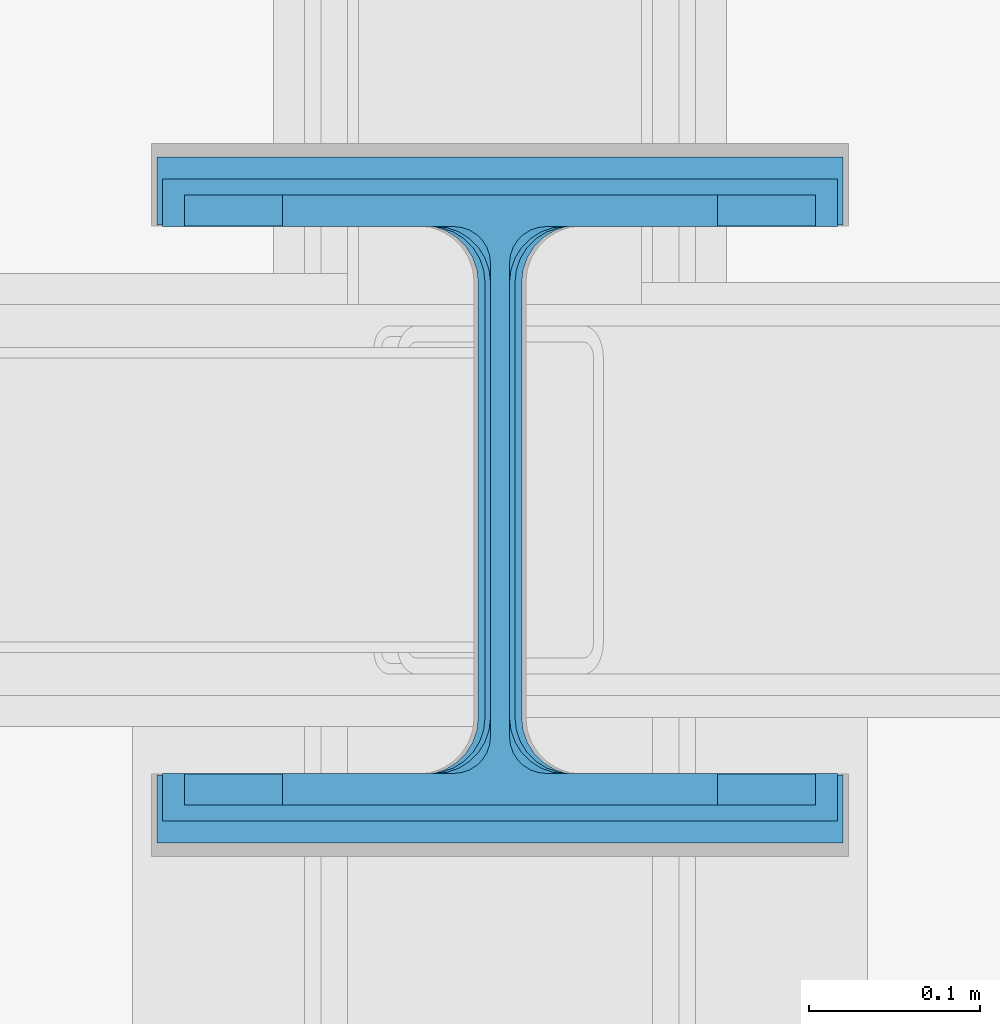
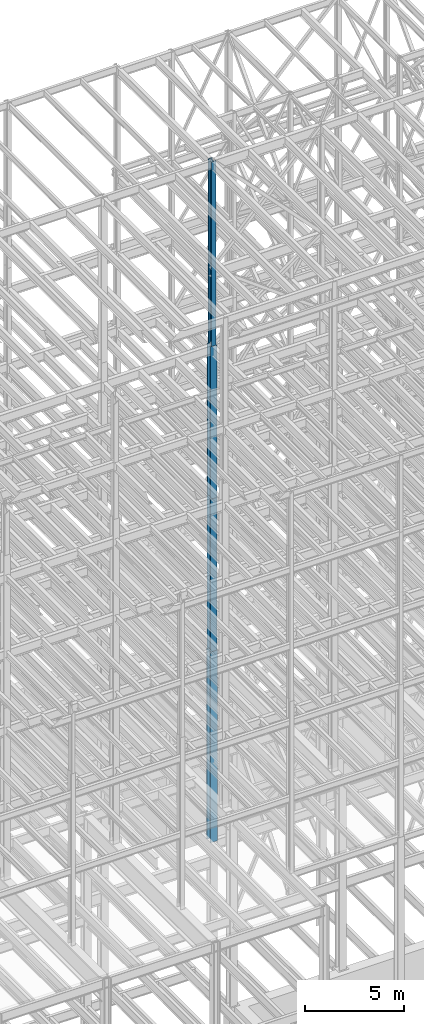
# One storey, part 36 of 150: 4 columns.
"""IFC2X3 building model written with IfcOpenShell, lengths in millimetres."""

import ifcopenshell
import ifcopenshell.guid

model = None  # the IFC model being written
_history = None  # IfcOwnerHistory: only IFC2X3 demands one
_inside = {}  # id of a spatial element -> (the spatial element, [elements in it])
_under = {}  # id of a project, library or spatial element -> (it, [spatial elements below it])
_declared = {}  # id of a project -> (the project, [libraries it declares])
_typed = {}  # id of a type object -> (the type object, [elements of that type])
_made_of = {}  # id of a material, layer set ... -> (it, [elements and type objects made of it])


def new_model(schema):
    """Start an empty IFC model of exactly this schema.

    Asked for "IFC4X3", IfcOpenShell would pick the latest addendum, in which some entities
    have other attributes; the version numbers below select the first issue.
    IFC2X3 requires an IfcOwnerHistory on every rooted entity: one is made here for all.
    """
    global model, _history
    if schema == "IFC4X3":
        model = ifcopenshell.file(schema_version=(4, 3, 0, 0))
    else:
        model = ifcopenshell.file(schema=schema)
    _inside.clear()
    _under.clear()
    _declared.clear()
    _typed.clear()
    _made_of.clear()
    _history = None
    if model.schema == "IFC2X3":
        org = make("IfcOrganization", Name="unknown")
        user = make(
            "IfcPersonAndOrganization",
            ThePerson=make("IfcPerson", FamilyName="unknown"),
            TheOrganization=org,
        )
        app = make(
            "IfcApplication",
            ApplicationDeveloper=org,
            Version="unknown",
            ApplicationFullName="unknown",
            ApplicationIdentifier="unknown",
        )
        _history = make(
            "IfcOwnerHistory",
            OwningUser=user,
            OwningApplication=app,
            ChangeAction="ADDED",
            CreationDate=0,
        )
    return model


def make(cls, **values):
    """One entity of the class cls with the attributes given. An attribute that is None is left unset."""
    return model.create_entity(
        cls, **{name: value for name, value in values.items() if value is not None}
    )


def rooted(cls, **values):
    """An entity with a GlobalId (a new one), such as an element, a storey or a relation."""
    return make(cls, GlobalId=ifcopenshell.guid.new(), OwnerHistory=_history, **values)


def si_unit(unit_type, name, prefix=None):
    """IfcSIUnit, for example si_unit("LENGTHUNIT", "METRE", prefix="MILLI")."""
    return make("IfcSIUnit", UnitType=unit_type, Prefix=prefix, Name=name)


def assignment(units):
    """IfcUnitAssignment: the units of a project."""
    return None if units is None else make("IfcUnitAssignment", Units=units)


def point(xyz):
    """IfcCartesianPoint."""
    return None if xyz is None else make("IfcCartesianPoint", Coordinates=xyz)


def direction(xyz):
    """IfcDirection."""
    return None if xyz is None else make("IfcDirection", DirectionRatios=xyz)


def frame(location, z_axis=None, x_axis=None):
    """IfcAxis2Placement3D, a coordinate frame: its origin and axes. An axis left out is left unset."""
    return make(
        "IfcAxis2Placement3D",
        Location=point(location),
        Axis=direction(z_axis),
        RefDirection=direction(x_axis),
    )


def frame_2d(location, x_axis=None):
    """IfcAxis2Placement2D, a coordinate frame in the plane: its origin and x axis."""
    return make(
        "IfcAxis2Placement2D", Location=point(location), RefDirection=direction(x_axis)
    )


def origin_with_axes():
    """The frame at (0, 0, 0) with the z axis (0, 0, 1) and the x axis (1, 0, 0) written out."""
    return frame((0.0, 0.0, 0.0), z_axis=(0.0, 0.0, 1.0), x_axis=(1.0, 0.0, 0.0))


def origin_2d_with_axis():
    """The frame at (0, 0) in the plane with the x axis (1, 0) written out."""
    return frame_2d((0.0, 0.0), x_axis=(1.0, 0.0))


def place(relative_to, where):
    """IfcLocalPlacement: puts the frame where relative to a parent placement (None: the world)."""
    return make(
        "IfcLocalPlacement", PlacementRelTo=relative_to, RelativePlacement=where
    )


def context(
    kind, dimensions, precision=None, world=None, true_north=None, identifier=None
):
    """IfcGeometricRepresentationContext, for example the 3D "Model" context."""
    return make(
        "IfcGeometricRepresentationContext",
        ContextIdentifier=identifier,
        ContextType=kind,
        CoordinateSpaceDimension=dimensions,
        Precision=precision,
        WorldCoordinateSystem=world,
        TrueNorth=true_north,
    )


def subcontext(parent, identifier, kind, view, scale=None):
    """IfcGeometricRepresentationSubContext, for example "Body" below "Model"."""
    return make(
        "IfcGeometricRepresentationSubContext",
        ContextIdentifier=identifier,
        ContextType=kind,
        ParentContext=parent,
        TargetScale=scale,
        TargetView=view,
    )


def project(units=None, contexts=None):
    """IfcProject with its units and contexts."""
    return rooted(
        "IfcProject",
        Name="project",
        RepresentationContexts=contexts,
        UnitsInContext=assignment(units),
    )


def spatial(cls, under=None, at=None, **own):
    """A site, building, storey or space (cls), placed at a placement, below another one or the project."""
    s = rooted(cls, ObjectPlacement=at, **own)
    if under is not None:
        _under.setdefault(under.id(), (under, []))[1].append(s)
    return s


def profile(cls, at=None, kind="AREA", **sizes):
    """A parametric profile (cls). Its sizes go by their IFC names, for example OverallWidth=200.0."""
    return make(cls, ProfileType=kind, Position=at, **sizes)


def i_section(**sizes):
    """IfcIShapeProfileDef."""
    return profile("IfcIShapeProfileDef", **sizes)


def extrude(swept, where, along, depth):
    """IfcExtrudedAreaSolid: the profile swept, set in the frame where, extruded along a direction by depth."""
    return make(
        "IfcExtrudedAreaSolid",
        SweptArea=swept,
        Position=where,
        ExtrudedDirection=direction(along),
        Depth=depth,
    )


def shape(context_of_items, identifier, shape_type, items):
    """IfcShapeRepresentation: the items that make up one representation, for example the "Body"."""
    return make(
        "IfcShapeRepresentation",
        ContextOfItems=context_of_items,
        RepresentationIdentifier=identifier,
        RepresentationType=shape_type,
        Items=items,
    )


def material(Name=None, Category=None):
    """IfcMaterial."""
    return make("IfcMaterial", Name=Name, Category=Category)


def made_of(thing, what):
    """Note that an element or type object is made of a material, layer set ...; save() writes the relation."""
    if what is not None:
        _made_of.setdefault(what.id(), (what, []))[1].append(thing)
    return thing


def type_object(cls, material=None, **own):
    """A type object (cls), such as IfcWallType, which elements share."""
    return made_of(rooted(cls, **own), material)


def element(
    cls,
    number,
    at=None,
    inside=None,
    cuts=None,
    type_object=None,
    material=None,
    context=None,
    identifier="Body",
    shape_type=None,
    held_by="IfcProductDefinitionShape",
    body=None,
    shapes=None,
    **own,
):
    """One element of the class cls, such as IfcWall. Its Tag is "e" and its number.

    at: its placement. inside: the storey or other place that contains it. cuts: it is an
    opening in that element (IfcRelVoidsElement). A single representation is given by context,
    identifier, shape_type and body (its items); several are given by shapes. held_by: the class
    of the entity that holds the representations. save() writes the other relations.
    """
    e = rooted(cls, Tag="e%d" % number, ObjectPlacement=at, **own)
    if body is not None:
        shapes = [shape(context, identifier, shape_type, body)]
    if shapes is not None:
        e.Representation = make(held_by, Representations=shapes)
    if inside is not None:
        _inside.setdefault(inside.id(), (inside, []))[1].append(e)
    if cuts is not None:
        rooted(
            "IfcRelVoidsElement", RelatingBuildingElement=cuts, RelatedOpeningElement=e
        )
    if type_object is not None:
        _typed.setdefault(type_object.id(), (type_object, []))[1].append(e)
    return made_of(e, material)


def aggregate(whole, parts):
    """IfcRelAggregates: a whole, such as a stair, and the parts it consists of."""
    return rooted("IfcRelAggregates", RelatingObject=whole, RelatedObjects=parts)


def save(model, path):
    """Write the relations noted so far, then the file.

    IfcRelAggregates (storeys below a building ...), IfcRelContainedInSpatialStructure (elements
    in a storey), IfcRelDefinesByType, IfcRelAssociatesMaterial and IfcRelDeclares: one each for
    every whole, place, type object, material and project.
    """
    for whole, parts in _under.values():
        aggregate(whole, parts)
    for where, things in _inside.values():
        rooted(
            "IfcRelContainedInSpatialStructure",
            RelatedElements=things,
            RelatingStructure=where,
        )
    for kind, things in _typed.values():
        rooted("IfcRelDefinesByType", RelatedObjects=things, RelatingType=kind)
    for what, things in _made_of.values():
        rooted("IfcRelAssociatesMaterial", RelatedObjects=things, RelatingMaterial=what)
    for by, libraries in _declared.values():
        rooted("IfcRelDeclares", RelatingContext=by, RelatedDefinitions=libraries)
    model.write(path)


model = new_model("IFC2X3")

# Units and contexts
model_context = context("Model", 3, precision=1e-05, world=origin_with_axes())
body_context = subcontext(model_context, "Body", "Model", "MODEL_VIEW")
ifc_project = project(units=[si_unit("LENGTHUNIT", "METRE", prefix="MILLI"), si_unit("AREAUNIT", "SQUARE_METRE"), si_unit("VOLUMEUNIT", "CUBIC_METRE"), si_unit("MASSUNIT", "GRAM", prefix="KILO"), si_unit("TIMEUNIT", "SECOND"), si_unit("PLANEANGLEUNIT", "RADIAN"), si_unit("SOLIDANGLEUNIT", "STERADIAN"), si_unit("THERMODYNAMICTEMPERATUREUNIT", "DEGREE_CELSIUS"), si_unit("LUMINOUSINTENSITYUNIT", "LUMEN")], contexts=[model_context])

# Site, building, storey
site_placement = place(None, origin_with_axes())
site = spatial("IfcSite", under=ifc_project, at=site_placement, CompositionType="ELEMENT")
building_placement = place(site_placement, origin_with_axes())
building = spatial("IfcBuilding", under=site, at=building_placement, Name="Undefined", CompositionType="ELEMENT")
storey_placement = place(building_placement, origin_with_axes())
storey = spatial("IfcBuildingStorey", under=building, at=storey_placement, Name="Undefined", CompositionType="ELEMENT", Elevation=0.0)

# Columns
ifc_material = material(Name="STEEL/A992")
column_type_1 = type_object("IfcColumnType", Name="W14X68", PredefinedType="NOTDEFINED")
column_1_placement = place(storey_placement, frame((50190.4, 22479.0, 54483.0), z_axis=(0.0, 0.0, 1.0), x_axis=(1.0, 0.0, 0.0)))
element("IfcColumn", 1, at=column_1_placement, inside=storey, type_object=column_type_1, material=ifc_material, Name="COLUMN", ObjectType="W14X68", context=body_context, shape_type="SweptSolid", body=[
    extrude(i_section(OverallWidth=254.0, OverallDepth=355.6, WebThickness=11.1125, FlangeThickness=18.288, FilletRadius=21.3994, at=origin_2d_with_axis()), frame((0.0, 0.0, 11430.0), z_axis=(0.0, 0.0, -1.0), x_axis=(-1.0, 0.0, 0.0)), (0.0, 0.0, 1.0), 11430.0),
])
column_type_2 = type_object("IfcColumnType", Name="W14X90", PredefinedType="NOTDEFINED")
column_2_placement = place(storey_placement, frame((50190.4, 22479.0, 45034.2), z_axis=(0.0, 0.0, 1.0), x_axis=(1.0, 0.0, 0.0)))
element("IfcColumn", 2, at=column_2_placement, inside=storey, type_object=column_type_2, material=ifc_material, Name="COLUMN", ObjectType="W14X90", context=body_context, shape_type="SweptSolid", body=[
    extrude(i_section(OverallWidth=368.3, OverallDepth=355.6, WebThickness=11.1125, FlangeThickness=18.034, FilletRadius=32.7659, at=origin_2d_with_axis()), frame((0.0, 0.0, 9448.8), z_axis=(0.0, 0.0, -1.0), x_axis=(-1.0, 0.0, 0.0)), (0.0, 0.0, 1.0), 9448.8),
])
column_type_3 = type_object("IfcColumnType", Name="W14X145", PredefinedType="NOTDEFINED")
column_3_placement = place(storey_placement, frame((50190.4, 22479.0, 35585.4), z_axis=(0.0, 0.0, 1.0), x_axis=(1.0, 0.0, 0.0)))
element("IfcColumn", 3, at=column_3_placement, inside=storey, type_object=column_type_3, material=ifc_material, Name="COLUMN", ObjectType="W14X145", context=body_context, shape_type="SweptSolid", body=[
    extrude(i_section(OverallWidth=393.7, OverallDepth=374.65, WebThickness=17.4625, FlangeThickness=27.686, FilletRadius=32.6389, at=origin_2d_with_axis()), frame((0.0, 0.0, 9448.8), z_axis=(0.0, 0.0, -1.0), x_axis=(-1.0, 0.0, 0.0)), (0.0, 0.0, 1.0), 9448.8),
])
column_type_4 = type_object("IfcColumnType", Name="W14X211", PredefinedType="NOTDEFINED")
column_4_placement = place(storey_placement, frame((50190.4, 22479.0, 23774.4), z_axis=(0.0, 0.0, 1.0), x_axis=(1.0, 0.0, 0.0)))
element("IfcColumn", 4, at=column_4_placement, inside=storey, type_object=column_type_4, material=ifc_material, Name="COLUMN", ObjectType="W14X211", context=body_context, shape_type="SweptSolid", body=[
    extrude(i_section(OverallWidth=400.05, OverallDepth=400.05, WebThickness=25.3999, FlangeThickness=39.624, FilletRadius=33.4009, at=origin_2d_with_axis()), frame((0.0, 0.0, 11811.0), z_axis=(0.0, 0.0, -1.0), x_axis=(-1.0, 0.0, 0.0)), (0.0, 0.0, 1.0), 11811.0),
])

save(model, "model.ifc")
